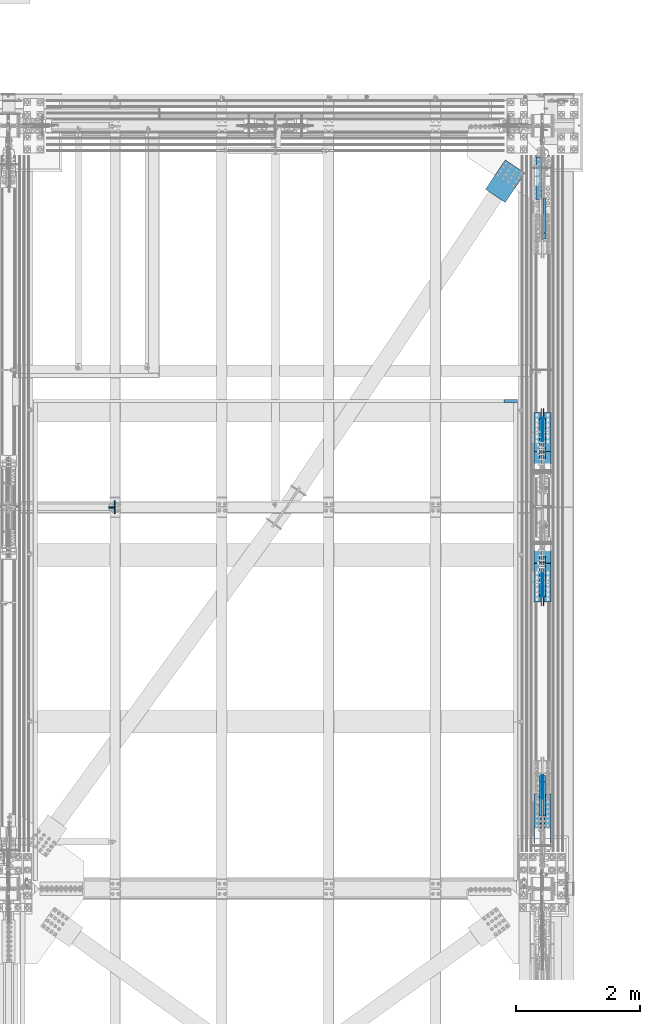
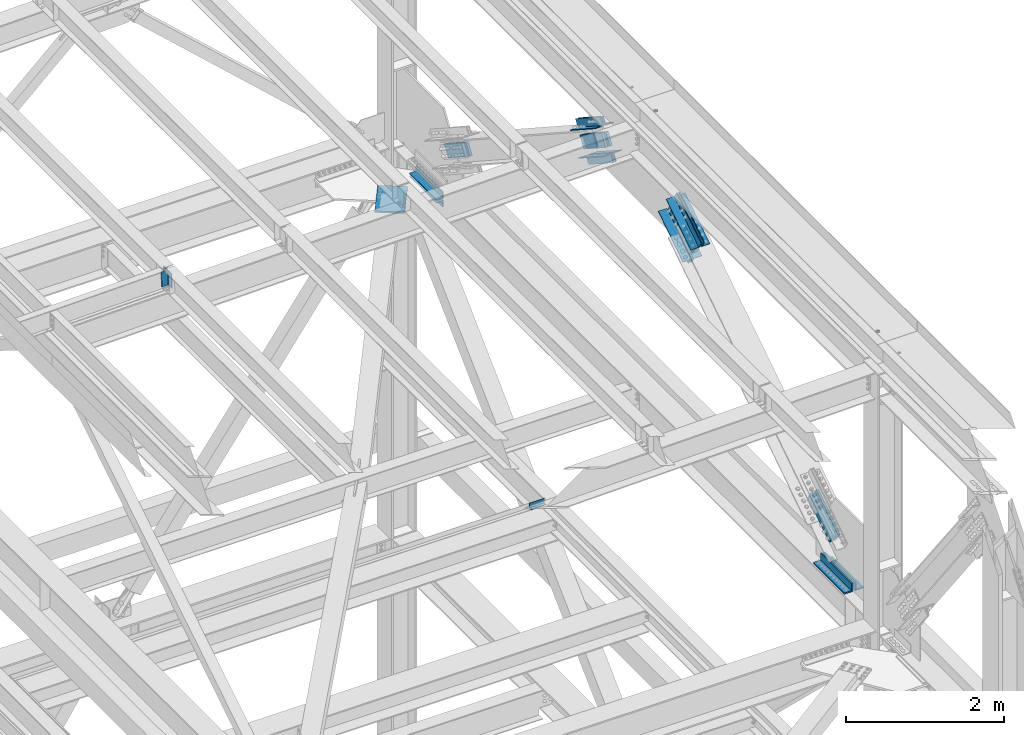
# One storey, part 2777 of 3843: 23 members, 6 beams, 8 elements without a shape of their own.
"""IFC2X3 building model written with IfcOpenShell, lengths in millimetres."""

from ifc_helpers import new_model, si_unit, frame, origin_with_axes, place, context, subcontext, project, spatial, faceted_brep, material, type_object, element, aggregate, save


model = new_model("IFC2X3")

# Units and contexts
model_context = context("Model", 3, precision=1e-05, world=origin_with_axes())
body_context = subcontext(model_context, "Body", "Model", "MODEL_VIEW")
ifc_project = project(units=[si_unit("LENGTHUNIT", "METRE", prefix="MILLI"), si_unit("AREAUNIT", "SQUARE_METRE"), si_unit("VOLUMEUNIT", "CUBIC_METRE"), si_unit("MASSUNIT", "GRAM", prefix="KILO"), si_unit("TIMEUNIT", "SECOND"), si_unit("PLANEANGLEUNIT", "RADIAN"), si_unit("SOLIDANGLEUNIT", "STERADIAN"), si_unit("THERMODYNAMICTEMPERATUREUNIT", "DEGREE_CELSIUS"), si_unit("LUMINOUSINTENSITYUNIT", "LUMEN")], contexts=[model_context])

# Site, building, storey
site_placement = place(None, origin_with_axes())
site = spatial("IfcSite", under=ifc_project, at=site_placement, CompositionType="ELEMENT")
building_placement = place(site_placement, origin_with_axes())
building = spatial("IfcBuilding", under=site, at=building_placement, Name="Undefined", CompositionType="ELEMENT")
storey_placement = place(building_placement, origin_with_axes())
storey = spatial("IfcBuildingStorey", under=building, at=storey_placement, Name="Undefined", CompositionType="ELEMENT", Elevation=0.0)

# Assembly, beams
assembly_1_placement = place(storey_placement, origin_with_axes())
assembly_1 = element("IfcElementAssembly", 1, at=assembly_1_placement, inside=storey, Name="PLATE", AssemblyPlace="NOTDEFINED", PredefinedType="RIGID_FRAME")
ifc_material_1 = material(Name="STEEL/A572-50")
beam_type_1 = type_object("IfcBeamType", Name="L4X4X1/2", PredefinedType="NOTDEFINED")
beam_1_placement = place(assembly_1_placement, frame((85591.6499999543, 103365.3, 42297.35), z_axis=(-1.0, 0.0, 0.0), x_axis=(0.0, 1.0, 0.0)))
beam_1 = element("IfcBeam", 2, at=beam_1_placement, type_object=beam_type_1, material=ifc_material_1, Name="ANGLE", ObjectType="L4X4X1/2", context=body_context, shape_type="Brep", body=[
    faceted_brep([(0.0, 50.8000000000029, -50.8000000000029), (0.0, 50.8000000000029, 50.8000000000029), (685.800000000003, 50.8000000000029, 50.8000000000029), (685.800000000003, 50.8000000000029, -50.8000000000029), (0.0, 38.0999999999985, 50.8000000000029), (685.800000000003, 38.0999999999985, 50.8000000000029), (0.0, 38.0999999999985, -38.0999999999985), (685.800000000003, 38.0999999999985, -38.1000000000058), (0.0, -50.8000000000029, -38.1000000000058), (685.800000000003, -50.8000000000029, -38.1000000000058), (0.0, -50.8000000000029, -50.8000000000029), (685.800000000003, -50.8000000000029, -50.8000000000029)], [[[0, 1, 2, 3]], [[1, 4, 5, 2]], [[4, 6, 7, 5]], [[6, 8, 9, 7]], [[8, 10, 11, 9]], [[10, 0, 3, 11]], [[5, 7, 9, 11, 3, 2]], [[10, 8, 6, 4, 1, 0]]]),
])
beam_2_placement = place(assembly_1_placement, frame((85591.6499999543, 104051.1, 42167.175), z_axis=(-1.0, 0.0, 0.0), x_axis=(0.0, -1.0, 0.0)))
beam_2 = element("IfcBeam", 3, at=beam_2_placement, type_object=beam_type_1, material=ifc_material_1, Name="ANGLE", ObjectType="L4X4X1/2", context=body_context, shape_type="Brep", body=[
    faceted_brep([(0.0, 50.8000000000029, -50.8000000000029), (0.0, 50.8000000000029, 50.8000000000029), (685.800000000003, 50.8000000000029, 50.8000000000029), (685.800000000003, 50.8000000000029, -50.8000000000029), (0.0, 38.0999999999985, 50.8000000000029), (685.800000000003, 38.0999999999985, 50.8000000000029), (0.0, 38.0999999999985, -38.0999999999985), (685.800000000003, 38.0999999999985, -38.1000000000058), (0.0, -50.8000000000029, -38.1000000000058), (685.800000000003, -50.8000000000029, -38.1000000000058), (0.0, -50.8000000000029, -50.8000000000029), (685.800000000003, -50.8000000000029, -50.8000000000029)], [[[0, 1, 2, 3]], [[1, 4, 5, 2]], [[4, 6, 7, 5]], [[6, 8, 9, 7]], [[8, 10, 11, 9]], [[10, 0, 3, 11]], [[5, 7, 9, 11, 3, 2]], [[10, 8, 6, 4, 1, 0]]]),
])
aggregate(assembly_1, [beam_1, beam_2])

# Assembly, members
assembly_2_placement = place(storey_placement, origin_with_axes())
assembly_2 = element("IfcElementAssembly", 4, at=assembly_2_placement, inside=storey, Name="BEAM", AssemblyPlace="NOTDEFINED", PredefinedType="RIGID_FRAME")
member_type_1 = type_object("IfcMemberType", Name="L4X4X3/8", PredefinedType="NOTDEFINED")
member_1_placement = place(assembly_2_placement, frame((78685.0968642702, 98440.8749999524, 46353.7300155141), z_axis=(0.0, 1.0, 0.0), x_axis=(-0.0211520980073474, 0.0, 0.999776269347241)))
member_1 = element("IfcMember", 5, at=member_1_placement, type_object=member_type_1, material=ifc_material_1, Name="ANGLE", ObjectType="L4X4X3/8", context=body_context, shape_type="Brep", body=[
    faceted_brep([(0.0, 50.8000000000029, -50.8000000000029), (0.0, 50.8000000000029, 50.8000000000029), (228.599999994367, 50.7999999996973, 50.8000000000029), (228.599999994367, 50.7999999996973, -50.8000000000029), (0.0, 41.2750000000015, 50.8000000000029), (228.599999994345, 41.2749999997031, 50.8000000000029), (0.0, 41.2749999999942, -41.2750000000015), (228.599999994345, 41.2749999997031, -41.2750000000015), (0.0, -50.8000000000029, -41.2750000000015), (228.599999994258, -50.8000000001412, -41.2750000000015), (0.0, -50.8000000000029, -50.8000000000029), (228.599999994258, -50.8000000001412, -50.8000000000029)], [[[0, 1, 2, 3]], [[1, 4, 5, 2]], [[4, 6, 7, 5]], [[6, 8, 9, 7]], [[8, 10, 11, 9]], [[10, 0, 3, 11]], [[5, 7, 9, 11, 3, 2]], [[10, 8, 6, 4, 1, 0]]]),
])
member_2_placement = place(assembly_2_placement, frame((78680.2614946649, 98332.9250000477, 46582.2788706815), z_axis=(0.0, -1.0, 0.0), x_axis=(0.0211520550054438, 0.0, -0.999776270257025)))
member_2 = element("IfcMember", 6, at=member_2_placement, type_object=member_type_1, material=ifc_material_1, Name="ANGLE", ObjectType="L4X4X3/8", context=body_context, shape_type="Brep", body=[
    faceted_brep([(0.0, 50.8000000000029, -50.8000000000029), (0.0, 50.8000000000029, 50.8000000000029), (228.599999994367, 50.7999999996973, 50.8000000000029), (228.599999994367, 50.7999999996973, -50.8000000000029), (0.0, 41.2750000000015, 50.8000000000029), (228.599999994345, 41.2749999997031, 50.8000000000029), (0.0, 41.2749999999942, -41.2750000000015), (228.599999994345, 41.2749999997031, -41.2750000000015), (0.0, -50.8000000000029, -41.2750000000015), (228.599999994258, -50.8000000001412, -41.2750000000015), (0.0, -50.8000000000029, -50.8000000000029), (228.599999994258, -50.8000000001412, -50.8000000000029)], [[[0, 1, 2, 3]], [[1, 4, 5, 2]], [[4, 6, 7, 5]], [[6, 8, 9, 7]], [[8, 10, 11, 9]], [[10, 0, 3, 11]], [[5, 7, 9, 11, 3, 2]], [[10, 8, 6, 4, 1, 0]]]),
])
aggregate(assembly_2, [member_1, member_2])

# Assembly, beam
assembly_3_placement = place(storey_placement, origin_with_axes())
assembly_3 = element("IfcElementAssembly", 7, at=assembly_3_placement, inside=storey, Name="BEAM", AssemblyPlace="NOTDEFINED", PredefinedType="RIGID_FRAME")
ifc_material_2 = material(Name="STEEL/A36")
beam_type_2 = type_object("IfcBeamType", PredefinedType="NOTDEFINED")
beam_3_placement = place(assembly_3_placement, frame((85140.80025, 100082.746884, 39627.175), z_axis=(-1.0, 0.0, 0.0), x_axis=(0.0, 1.0, 0.0)))
beam_3 = element("IfcBeam", 8, at=beam_3_placement, type_object=beam_type_2, material=ifc_material_2, Name="BENT_PLATE", context=body_context, shape_type="Brep", body=[
    faceted_brep([(0.0, -4.76939021609724e-08, 112.713000000003), (0.0, -3.17500000000291, 109.538000047687), (44.4499999999825, -3.17500000000291, 109.538000047687), (47.6249999522843, -4.76939021609724e-08, 112.713000000003), (44.4499999999825, -73.0249999999942, 109.538000047687), (47.6249999522843, -73.0249999999942, 112.713000000003), (44.4499999999825, -3.17500000000291, -112.713000000003), (44.4499999999825, -73.0249999999942, -112.713000000003), (0.0, 3.17500000000291, 112.713000000003), (0.0, 3.17500000000291, -112.713000000003), (0.0, -3.17500000000291, -112.713000000003), (50.7999999999884, 3.17500000000291, 112.713000000003), (50.7999999999884, 3.17500000000291, -112.713000000003), (50.7999999999884, -73.0249999999942, 112.713000000003), (50.7999999999884, -73.0249999999942, -112.713000000003)], [[[0, 1, 2, 3]], [[3, 2, 4, 5]], [[6, 7, 4, 2]], [[8, 9, 10, 1, 0]], [[9, 8, 11, 12]], [[10, 6, 2, 1]], [[12, 11, 13, 14]], [[13, 11, 8, 0, 3, 5]], [[6, 10, 9, 12, 14, 7]], [[7, 14, 13, 5, 4]]]),
])
aggregate(assembly_3, [beam_3])

assembly_4_placement = place(storey_placement, origin_with_axes())
assembly_4 = element("IfcElementAssembly", 9, at=assembly_4_placement, inside=storey, AssemblyPlace="NOTDEFINED", PredefinedType="RIGID_FRAME")
beam_type_3 = type_object("IfcBeamType", PredefinedType="NOTDEFINED")
beam_4_placement = place(assembly_4_placement, frame((85206.283004064, 103899.396746269, 42259.25), z_axis=(-0.830469590040634, 0.55706396402724, 0.0), x_axis=(-0.557063965179534, -0.830469589267695, 0.0)))
beam_4 = element("IfcBeam", 10, at=beam_4_placement, type_object=beam_type_3, material=ifc_material_1, Name="PLATE", context=body_context, shape_type="Brep", body=[
    faceted_brep([(5.85714587941766e-10, 12.6999999999971, -190.500000000349), (-6.14818418398499e-10, 12.6999999999971, 190.500000000364), (571.499999996191, 12.6999999999971, 190.49999999936), (571.499999997392, 12.6999999999971, -190.500000001353), (-6.14818418398499e-10, -12.6999999999971, 190.500000000364), (571.499999996191, -12.6999999999971, 190.49999999936), (5.85714587941766e-10, -12.6999999999971, -190.500000000349), (571.499999997392, -12.6999999999971, -190.500000001353)], [[[0, 1, 2, 3]], [[1, 4, 5, 2]], [[4, 6, 7, 5]], [[6, 0, 3, 7]], [[5, 7, 3, 2]], [[6, 4, 1, 0]]]),
])
aggregate(assembly_4, [beam_4])

# Assembly, member
assembly_5_placement = place(storey_placement, origin_with_axes())
assembly_5 = element("IfcElementAssembly", 11, at=assembly_5_placement, inside=storey, AssemblyPlace="NOTDEFINED", PredefinedType="RIGID_FRAME")
member_type_2 = type_object("IfcMemberType", PredefinedType="NOTDEFINED")
member_3_placement = place(assembly_5_placement, frame((85680.5499998689, 103329.322101915, 42997.8950808007), z_axis=(0.0, -0.545564039261356, -0.838069137401464), x_axis=(0.0, -0.838069137401467, 0.545564039261351)))
member_3 = element("IfcMember", 12, at=member_3_placement, type_object=member_type_2, material=ifc_material_1, Name="PLATE", context=body_context, shape_type="Brep", body=[
    faceted_brep([(1.16415321826935e-10, 19.0500000000029, -95.2500000001601), (-1.16415321826935e-10, 19.0500000000029, 95.2500000001601), (660.400000008245, 19.0500000000029, 95.2500000025429), (660.400000007954, 19.0500000000029, -95.2499999980901), (-1.16415321826935e-10, -19.0500000000029, 95.2500000001601), (660.400000008245, -19.0500000000029, 95.2500000025429), (1.16415321826935e-10, -19.0500000000029, -95.2500000001601), (660.400000007954, -19.0500000000029, -95.2499999980901)], [[[0, 1, 2, 3]], [[1, 4, 5, 2]], [[4, 6, 7, 5]], [[6, 0, 3, 7]], [[5, 7, 3, 2]], [[6, 4, 1, 0]]]),
])

# Assembly, members
assembly_6_placement = place(storey_placement, origin_with_axes())
assembly_6 = element("IfcElementAssembly", 13, at=assembly_6_placement, inside=storey, AssemblyPlace="NOTDEFINED", PredefinedType="RIGID_FRAME")
member_4_placement = place(assembly_6_placement, frame((85680.5499999863, 93444.4779012868, 42997.895080809), z_axis=(0.0, -0.545564039261356, 0.838069137401464), x_axis=(0.0, 0.838069137401467, 0.545564039261351)))
member_4 = element("IfcMember", 14, at=member_4_placement, type_object=member_type_2, material=ifc_material_1, Name="PLATE", context=body_context, shape_type="Brep", body=[
    faceted_brep([(1.16415321826935e-10, 19.0500000000029, -95.2500000001601), (-1.16415321826935e-10, 19.0500000000029, 95.2500000001601), (660.400000008245, 19.0500000000029, 95.2500000025429), (660.400000007954, 19.0500000000029, -95.2499999980901), (-1.16415321826935e-10, -19.0500000000029, 95.2500000001601), (660.400000008245, -19.0500000000029, 95.2500000025429), (1.16415321826935e-10, -19.0500000000029, -95.2500000001601), (660.400000007954, -19.0500000000029, -95.2499999980901)], [[[0, 1, 2, 3]], [[1, 4, 5, 2]], [[4, 6, 7, 5]], [[6, 0, 3, 7]], [[5, 7, 3, 2]], [[6, 4, 1, 0]]]),
])
member_5_placement = place(assembly_6_placement, frame((85617.0499999863, 93444.4779012868, 42997.895080809), z_axis=(0.0, -0.545564039261356, 0.838069137401464), x_axis=(0.0, 0.838069137401467, 0.545564039261351)))
member_5 = element("IfcMember", 15, at=member_5_placement, type_object=member_type_2, material=ifc_material_1, Name="PLATE", context=body_context, shape_type="Brep", body=[
    faceted_brep([(1.16415321826935e-10, 19.0500000000029, -95.2500000001601), (-1.16415321826935e-10, 19.0500000000029, 95.2500000001601), (660.400000008245, 19.0500000000029, 95.2500000025429), (660.400000007954, 19.0500000000029, -95.2499999980901), (-1.16415321826935e-10, -19.0500000000029, 95.2500000001601), (660.400000008245, -19.0500000000029, 95.2500000025429), (1.16415321826935e-10, -19.0500000000029, -95.2500000001601), (660.400000007954, -19.0500000000029, -95.2499999980901)], [[[0, 1, 2, 3]], [[1, 4, 5, 2]], [[4, 6, 7, 5]], [[6, 0, 3, 7]], [[5, 7, 3, 2]], [[6, 4, 1, 0]]]),
])

# Member
member_6_placement = place(assembly_5_placement, frame((85680.5499999863, 99226.2437681716, 45668.9062053753), z_axis=(0.0, 0.545564039261343, 0.838069137401472), x_axis=(0.0, 0.838069137401467, -0.545564039261352)))
member_6 = element("IfcMember", 16, at=member_6_placement, type_object=member_type_2, material=ifc_material_1, Name="PLATE", context=body_context, shape_type="Brep", body=[
    faceted_brep([(1.16415321826935e-10, 19.0500000000029, -95.2500000001601), (-1.16415321826935e-10, 19.0500000000029, 95.2500000001601), (660.400000008245, 19.0500000000029, 95.2500000025429), (660.400000007954, 19.0500000000029, -95.2499999980901), (-1.16415321826935e-10, -19.0500000000029, 95.2500000001601), (660.400000008245, -19.0500000000029, 95.2500000025429), (1.16415321826935e-10, -19.0500000000029, -95.2500000001601), (660.400000007954, -19.0500000000029, -95.2499999980901)], [[[0, 1, 2, 3]], [[1, 4, 5, 2]], [[4, 6, 7, 5]], [[6, 0, 3, 7]], [[5, 7, 3, 2]], [[6, 4, 1, 0]]]),
])

member_7_placement = place(assembly_5_placement, frame((85617.0499999863, 99226.2437681716, 45668.9062053753), z_axis=(0.0, 0.545564039261343, 0.838069137401472), x_axis=(0.0, 0.838069137401467, -0.545564039261352)))
member_7 = element("IfcMember", 17, at=member_7_placement, type_object=member_type_2, material=ifc_material_1, Name="PLATE", context=body_context, shape_type="Brep", body=[
    faceted_brep([(1.16415321826935e-10, 19.0500000000029, -95.2500000001601), (-1.16415321826935e-10, 19.0500000000029, 95.2500000001601), (660.400000008245, 19.0500000000029, 95.2500000025429), (660.400000007954, 19.0500000000029, -95.2499999980901), (-1.16415321826935e-10, -19.0500000000029, 95.2500000001601), (660.400000008245, -19.0500000000029, 95.2500000025429), (1.16415321826935e-10, -19.0500000000029, -95.2500000001601), (660.400000007954, -19.0500000000029, -95.2499999980901)], [[[0, 1, 2, 3]], [[1, 4, 5, 2]], [[4, 6, 7, 5]], [[6, 0, 3, 7]], [[5, 7, 3, 2]], [[6, 4, 1, 0]]]),
])

member_8_placement = place(assembly_6_placement, frame((85680.5499999863, 97547.556235026, 45668.9062053805), z_axis=(0.0, 0.545564039261343, -0.838069137401472), x_axis=(0.0, -0.838069137401464, -0.545564039261356)))
member_8 = element("IfcMember", 18, at=member_8_placement, type_object=member_type_2, material=ifc_material_1, Name="PLATE", context=body_context, shape_type="Brep", body=[
    faceted_brep([(1.16415321826935e-10, 19.0500000000029, -95.2500000001601), (-1.16415321826935e-10, 19.0500000000029, 95.2500000001601), (660.400000008245, 19.0500000000029, 95.2500000025429), (660.400000007954, 19.0500000000029, -95.2499999980901), (-1.16415321826935e-10, -19.0500000000029, 95.2500000001601), (660.400000008245, -19.0500000000029, 95.2500000025429), (1.16415321826935e-10, -19.0500000000029, -95.2500000001601), (660.400000007954, -19.0500000000029, -95.2499999980901)], [[[0, 1, 2, 3]], [[1, 4, 5, 2]], [[4, 6, 7, 5]], [[6, 0, 3, 7]], [[5, 7, 3, 2]], [[6, 4, 1, 0]]]),
])

member_9_placement = place(assembly_6_placement, frame((85617.0499999863, 97547.556235026, 45668.9062053805), z_axis=(0.0, 0.545564039261343, -0.838069137401472), x_axis=(0.0, -0.838069137401464, -0.545564039261356)))
member_9 = element("IfcMember", 19, at=member_9_placement, type_object=member_type_2, material=ifc_material_1, Name="PLATE", context=body_context, shape_type="Brep", body=[
    faceted_brep([(1.16415321826935e-10, 19.0500000000029, -95.2500000001601), (-1.16415321826935e-10, 19.0500000000029, 95.2500000001601), (660.400000008245, 19.0500000000029, 95.2500000025429), (660.400000007954, 19.0500000000029, -95.2499999980901), (-1.16415321826935e-10, -19.0500000000029, 95.2500000001601), (660.400000008245, -19.0500000000029, 95.2500000025429), (1.16415321826935e-10, -19.0500000000029, -95.2500000001601), (660.400000007954, -19.0500000000029, -95.2499999980901)], [[[0, 1, 2, 3]], [[1, 4, 5, 2]], [[4, 6, 7, 5]], [[6, 0, 3, 7]], [[5, 7, 3, 2]], [[6, 4, 1, 0]]]),
])

member_type_3 = type_object("IfcMemberType", Name="L5X5X1/2", PredefinedType="NOTDEFINED")
member_10_placement = place(assembly_5_placement, frame((85724.9999999863, 99320.6361976878, 45895.3826097803), z_axis=(0.0, 0.545564039261343, 0.838069137401472), x_axis=(0.0, 0.838069137401467, -0.545564039261352)))
member_10 = element("IfcMember", 20, at=member_10_placement, type_object=member_type_3, material=ifc_material_1, Name="ANGLE", ObjectType="L5X5X1/2", context=body_context, shape_type="Brep", body=[
    faceted_brep([(-1.01863406598568e-10, 63.5, -63.5000000002037), (1.01863406598568e-10, 63.5, 63.5000000002074), (749.300000016152, 63.5, 63.4999999992142), (749.300000016028, 63.5, -63.5000000006548), (1.01863406598568e-10, 50.8000000000029, 63.5000000002074), (749.300000016152, 50.8000000000029, 63.4999999992142), (0.0, 50.8000000000029, -50.8000000000029), (749.30000001605, 50.8000000000029, -50.8000000006577), (-7.27595761418343e-11, -63.5, -50.8000000001666), (749.30000001605, -63.5, -50.8000000006577), (-1.01863406598568e-10, -63.5, -63.5000000002037), (749.300000016028, -63.5, -63.5000000006548)], [[[0, 1, 2, 3]], [[1, 4, 5, 2]], [[4, 6, 7, 5]], [[6, 8, 9, 7]], [[8, 10, 11, 9]], [[10, 0, 3, 11]], [[5, 7, 9, 11, 3, 2]], [[10, 8, 6, 4, 1, 0]]]),
])

member_11_placement = place(assembly_5_placement, frame((85724.9999999863, 99685.3121970061, 45082.1393094363), z_axis=(0.0, -0.545564039261356, -0.838069137401464), x_axis=(0.0, -0.838069137401467, 0.545564039261351)))
member_11 = element("IfcMember", 21, at=member_11_placement, type_object=member_type_3, material=ifc_material_1, Name="ANGLE", ObjectType="L5X5X1/2", context=body_context, shape_type="Brep", body=[
    faceted_brep([(-1.01863406598568e-10, 63.5, -63.5000000002037), (1.01863406598568e-10, 63.5, 63.5000000002074), (749.300000016152, 63.5, 63.4999999992142), (749.300000016028, 63.5, -63.5000000006548), (1.01863406598568e-10, 50.8000000000029, 63.5000000002074), (749.300000016152, 50.8000000000029, 63.4999999992142), (0.0, 50.8000000000029, -50.8000000000029), (749.30000001605, 50.8000000000029, -50.8000000006577), (-7.27595761418343e-11, -63.5, -50.8000000001666), (749.30000001605, -63.5, -50.8000000006577), (-1.01863406598568e-10, -63.5, -63.5000000002037), (749.300000016028, -63.5, -63.5000000006548)], [[[0, 1, 2, 3]], [[1, 4, 5, 2]], [[4, 6, 7, 5]], [[6, 8, 9, 7]], [[8, 10, 11, 9]], [[10, 0, 3, 11]], [[5, 7, 9, 11, 3, 2]], [[10, 8, 6, 4, 1, 0]]]),
])

member_12_placement = place(assembly_5_placement, frame((85572.5999999863, 99948.6014023575, 45486.5914751536), z_axis=(0.0, 0.545564039261343, 0.838069137401472), x_axis=(0.0, -0.838069137401467, 0.545564039261351)))
member_12 = element("IfcMember", 22, at=member_12_placement, type_object=member_type_3, material=ifc_material_1, Name="ANGLE", ObjectType="L5X5X1/2", context=body_context, shape_type="Brep", body=[
    faceted_brep([(-1.01863406598568e-10, 63.5, -63.5000000002037), (1.01863406598568e-10, 63.5, 63.5000000002074), (749.300000016152, 63.5, 63.4999999992142), (749.300000016028, 63.5, -63.5000000006548), (1.01863406598568e-10, 50.8000000000029, 63.5000000002074), (749.300000016152, 50.8000000000029, 63.4999999992142), (0.0, 50.8000000000029, -50.8000000000029), (749.30000001605, 50.8000000000029, -50.8000000006577), (-7.27595761418343e-11, -63.5, -50.8000000001666), (749.30000001605, -63.5, -50.8000000006577), (-1.01863406598568e-10, -63.5, -63.5000000002037), (749.300000016028, -63.5, -63.5000000006548)], [[[0, 1, 2, 3]], [[1, 4, 5, 2]], [[4, 6, 7, 5]], [[6, 8, 9, 7]], [[8, 10, 11, 9]], [[10, 0, 3, 11]], [[5, 7, 9, 11, 3, 2]], [[10, 8, 6, 4, 1, 0]]]),
])

member_13_placement = place(assembly_5_placement, frame((85572.5999999863, 99057.3469923364, 45490.930444063), z_axis=(0.0, -0.545564039261356, -0.838069137401464), x_axis=(0.0, 0.838069137401467, -0.545564039261352)))
member_13 = element("IfcMember", 23, at=member_13_placement, type_object=member_type_3, material=ifc_material_1, Name="ANGLE", ObjectType="L5X5X1/2", context=body_context, shape_type="Brep", body=[
    faceted_brep([(-1.01863406598568e-10, 63.5, -63.5000000002037), (1.01863406598568e-10, 63.5, 63.5000000002074), (749.300000016152, 63.5, 63.4999999992142), (749.300000016028, 63.5, -63.5000000006548), (1.01863406598568e-10, 50.8000000000029, 63.5000000002074), (749.300000016152, 50.8000000000029, 63.4999999992142), (0.0, 50.8000000000029, -50.8000000000029), (749.30000001605, 50.8000000000029, -50.8000000006577), (-7.27595761418343e-11, -63.5, -50.8000000001666), (749.30000001605, -63.5, -50.8000000006577), (-1.01863406598568e-10, -63.5, -63.5000000002037), (749.300000016028, -63.5, -63.5000000006548)], [[[0, 1, 2, 3]], [[1, 4, 5, 2]], [[4, 6, 7, 5]], [[6, 8, 9, 7]], [[8, 10, 11, 9]], [[10, 0, 3, 11]], [[5, 7, 9, 11, 3, 2]], [[10, 8, 6, 4, 1, 0]]]),
])

member_14_placement = place(assembly_6_placement, frame((85724.9999999863, 97716.4530108612, 45490.9304440682), z_axis=(0.0, 0.545564039261343, -0.838069137401472), x_axis=(0.0, -0.838069137401464, -0.545564039261356)))
member_14 = element("IfcMember", 24, at=member_14_placement, type_object=member_type_3, material=ifc_material_1, Name="ANGLE", ObjectType="L5X5X1/2", context=body_context, shape_type="Brep", body=[
    faceted_brep([(-1.01863406598568e-10, 63.5, -63.5000000002037), (1.01863406598568e-10, 63.5, 63.5000000002074), (749.300000016152, 63.5, 63.4999999992142), (749.300000016028, 63.5, -63.5000000006548), (1.01863406598568e-10, 50.8000000000029, 63.5000000002074), (749.300000016152, 50.8000000000029, 63.4999999992142), (0.0, 50.8000000000029, -50.8000000000029), (749.30000001605, 50.8000000000029, -50.8000000006577), (-7.27595761418343e-11, -63.5, -50.8000000001666), (749.30000001605, -63.5, -50.8000000006577), (-1.01863406598568e-10, -63.5, -63.5000000002037), (749.300000016028, -63.5, -63.5000000006548)], [[[0, 1, 2, 3]], [[1, 4, 5, 2]], [[4, 6, 7, 5]], [[6, 8, 9, 7]], [[8, 10, 11, 9]], [[10, 0, 3, 11]], [[5, 7, 9, 11, 3, 2]], [[10, 8, 6, 4, 1, 0]]]),
])

member_15_placement = place(assembly_6_placement, frame((85724.9999999863, 96825.19860084, 45486.5914751588), z_axis=(0.0, -0.545564039261356, 0.838069137401464), x_axis=(0.0, 0.838069137401467, 0.545564039261351)))
member_15 = element("IfcMember", 25, at=member_15_placement, type_object=member_type_3, material=ifc_material_1, Name="ANGLE", ObjectType="L5X5X1/2", context=body_context, shape_type="Brep", body=[
    faceted_brep([(-1.01863406598568e-10, 63.5, -63.5000000002037), (1.01863406598568e-10, 63.5, 63.5000000002074), (749.300000016152, 63.5, 63.4999999992142), (749.300000016028, 63.5, -63.5000000006548), (1.01863406598568e-10, 50.8000000000029, 63.5000000002074), (749.300000016152, 50.8000000000029, 63.4999999992142), (0.0, 50.8000000000029, -50.8000000000029), (749.30000001605, 50.8000000000029, -50.8000000006577), (-7.27595761418343e-11, -63.5, -50.8000000001666), (749.30000001605, -63.5, -50.8000000006577), (-1.01863406598568e-10, -63.5, -63.5000000002037), (749.300000016028, -63.5, -63.5000000006548)], [[[0, 1, 2, 3]], [[1, 4, 5, 2]], [[4, 6, 7, 5]], [[6, 8, 9, 7]], [[8, 10, 11, 9]], [[10, 0, 3, 11]], [[5, 7, 9, 11, 3, 2]], [[10, 8, 6, 4, 1, 0]]]),
])

member_16_placement = place(assembly_6_placement, frame((85572.5999999863, 97088.4878061914, 45082.1393094415), z_axis=(0.0, 0.545564039261343, -0.838069137401472), x_axis=(0.0, 0.838069137401467, 0.545564039261351)))
member_16 = element("IfcMember", 26, at=member_16_placement, type_object=member_type_3, material=ifc_material_1, Name="ANGLE", ObjectType="L5X5X1/2", context=body_context, shape_type="Brep", body=[
    faceted_brep([(-1.01863406598568e-10, 63.5, -63.5000000002037), (1.01863406598568e-10, 63.5, 63.5000000002074), (749.300000016152, 63.5, 63.4999999992142), (749.300000016028, 63.5, -63.5000000006548), (1.01863406598568e-10, 50.8000000000029, 63.5000000002074), (749.300000016152, 50.8000000000029, 63.4999999992142), (0.0, 50.8000000000029, -50.8000000000029), (749.30000001605, 50.8000000000029, -50.8000000006577), (-7.27595761418343e-11, -63.5, -50.8000000001666), (749.30000001605, -63.5, -50.8000000006577), (-1.01863406598568e-10, -63.5, -63.5000000002037), (749.300000016028, -63.5, -63.5000000006548)], [[[0, 1, 2, 3]], [[1, 4, 5, 2]], [[4, 6, 7, 5]], [[6, 8, 9, 7]], [[8, 10, 11, 9]], [[10, 0, 3, 11]], [[5, 7, 9, 11, 3, 2]], [[10, 8, 6, 4, 1, 0]]]),
])

member_17_placement = place(assembly_6_placement, frame((85572.5999999863, 97453.1638055098, 45895.3826097856), z_axis=(0.0, -0.545564039261356, 0.838069137401464), x_axis=(0.0, -0.838069137401464, -0.545564039261356)))
member_17 = element("IfcMember", 27, at=member_17_placement, type_object=member_type_3, material=ifc_material_1, Name="ANGLE", ObjectType="L5X5X1/2", context=body_context, shape_type="Brep", body=[
    faceted_brep([(-1.01863406598568e-10, 63.5, -63.5000000002037), (1.01863406598568e-10, 63.5, 63.5000000002074), (749.300000016152, 63.5, 63.4999999992142), (749.300000016028, 63.5, -63.5000000006548), (1.01863406598568e-10, 50.8000000000029, 63.5000000002074), (749.300000016152, 50.8000000000029, 63.4999999992142), (0.0, 50.8000000000029, -50.8000000000029), (749.30000001605, 50.8000000000029, -50.8000000006577), (-7.27595761418343e-11, -63.5, -50.8000000001666), (749.30000001605, -63.5, -50.8000000006577), (-1.01863406598568e-10, -63.5, -63.5000000002037), (749.300000016028, -63.5, -63.5000000006548)], [[[0, 1, 2, 3]], [[1, 4, 5, 2]], [[4, 6, 7, 5]], [[6, 8, 9, 7]], [[8, 10, 11, 9]], [[10, 0, 3, 11]], [[5, 7, 9, 11, 3, 2]], [[10, 8, 6, 4, 1, 0]]]),
])

member_type_4 = type_object("IfcMemberType", PredefinedType="NOTDEFINED")
member_18_placement = place(assembly_6_placement, frame((85657.5312499863, 93726.5300694836, 43181.5046582246), z_axis=(0.0, -0.545564039261356, 0.838069137401464), x_axis=(0.0, 0.838069137401467, 0.545564039261351)))
member_18 = element("IfcMember", 28, at=member_18_placement, type_object=member_type_4, material=ifc_material_1, Name="PLATE", context=body_context, shape_type="Brep", body=[
    faceted_brep([(0.0, 3.17499999999927, -95.25), (-2.44140610448085e-05, 3.17500000000291, 95.2499999999927), (323.850000004109, 3.17500000000291, 95.2500000014152), (323.850000003833, 3.17500000000291, -95.2499999992106), (0.0, -3.17499999999927, 95.25), (323.850000004109, -3.17500000000291, 95.2500000014152), (0.0, -3.17499999999927, -95.25), (323.850000003833, -3.17500000000291, -95.2499999992106)], [[[0, 1, 2, 3]], [[1, 4, 5, 2]], [[4, 6, 7, 5]], [[6, 0, 3, 7]], [[5, 7, 3, 2]], [[6, 4, 1, 0]]]),
])

member_19_placement = place(assembly_6_placement, frame((85640.0687499863, 93726.5300694836, 43181.5046582246), z_axis=(0.0, -0.545564039261356, 0.838069137401464), x_axis=(0.0, 0.838069137401467, 0.545564039261351)))
member_19 = element("IfcMember", 29, at=member_19_placement, type_object=member_type_4, material=ifc_material_1, Name="PLATE", context=body_context, shape_type="Brep", body=[
    faceted_brep([(0.0, 3.17499999999927, -95.25), (-2.44140610448085e-05, 3.17500000000291, 95.2499999999927), (323.850000004109, 3.17500000000291, 95.2500000014152), (323.850000003833, 3.17500000000291, -95.2499999992106), (0.0, -3.17499999999927, 95.25), (323.850000004109, -3.17500000000291, 95.2500000014152), (0.0, -3.17499999999927, -95.25), (323.850000003833, -3.17500000000291, -95.2499999992106)], [[[0, 1, 2, 3]], [[1, 4, 5, 2]], [[4, 6, 7, 5]], [[6, 0, 3, 7]], [[5, 7, 3, 2]], [[6, 4, 1, 0]]]),
])

member_20_placement = place(assembly_5_placement, frame((85658.3249999863, 99508.2959363695, 45485.296627959), z_axis=(0.0, 0.545564039261343, 0.838069137401472), x_axis=(0.0, 0.838069137401467, -0.545564039261352)))
member_20 = element("IfcMember", 30, at=member_20_placement, type_object=member_type_4, material=ifc_material_1, Name="PLATE", context=body_context, shape_type="Brep", body=[
    faceted_brep([(0.0, 3.17499999999927, -95.25), (-2.44140610448085e-05, 3.17500000000291, 95.2499999999927), (323.850000004109, 3.17500000000291, 95.2500000014152), (323.850000003833, 3.17500000000291, -95.2499999992106), (0.0, -3.17499999999927, 95.25), (323.850000004109, -3.17500000000291, 95.2500000014152), (0.0, -3.17499999999927, -95.25), (323.850000003833, -3.17500000000291, -95.2499999992106)], [[[0, 1, 2, 3]], [[1, 4, 5, 2]], [[4, 6, 7, 5]], [[6, 0, 3, 7]], [[5, 7, 3, 2]], [[6, 4, 1, 0]]]),
])

member_21_placement = place(assembly_5_placement, frame((85639.2749999863, 99508.2959363695, 45485.296627959), z_axis=(0.0, -0.545564039261356, -0.838069137401464), x_axis=(0.0, 0.838069137401467, -0.545564039261352)))
member_21 = element("IfcMember", 31, at=member_21_placement, type_object=member_type_4, material=ifc_material_1, Name="PLATE", context=body_context, shape_type="Brep", body=[
    faceted_brep([(0.0, 3.17499999999927, -95.25), (-2.44140610448085e-05, 3.17500000000291, 95.2499999999927), (323.850000004109, 3.17500000000291, 95.2500000014152), (323.850000003833, 3.17500000000291, -95.2499999992106), (0.0, -3.17499999999927, 95.25), (323.850000004109, -3.17500000000291, 95.2500000014152), (0.0, -3.17499999999927, -95.25), (323.850000003833, -3.17500000000291, -95.2499999992106)], [[[0, 1, 2, 3]], [[1, 4, 5, 2]], [[4, 6, 7, 5]], [[6, 0, 3, 7]], [[5, 7, 3, 2]], [[6, 4, 1, 0]]]),
])

aggregate(assembly_5, [member_3, member_10, member_11, member_6, member_12, member_13, member_20, member_21, member_7])

member_22_placement = place(assembly_6_placement, frame((85658.3249999863, 97265.504066828, 45485.2966279642), z_axis=(0.0, 0.545564039261343, -0.838069137401472), x_axis=(0.0, -0.838069137401464, -0.545564039261356)))
member_22 = element("IfcMember", 32, at=member_22_placement, type_object=member_type_4, material=ifc_material_1, Name="PLATE", context=body_context, shape_type="Brep", body=[
    faceted_brep([(0.0, 3.17499999999927, -95.25), (-2.44140610448085e-05, 3.17500000000291, 95.2499999999927), (323.850000004109, 3.17500000000291, 95.2500000014152), (323.850000003833, 3.17500000000291, -95.2499999992106), (0.0, -3.17499999999927, 95.25), (323.850000004109, -3.17500000000291, 95.2500000014152), (0.0, -3.17499999999927, -95.25), (323.850000003833, -3.17500000000291, -95.2499999992106)], [[[0, 1, 2, 3]], [[1, 4, 5, 2]], [[4, 6, 7, 5]], [[6, 0, 3, 7]], [[5, 7, 3, 2]], [[6, 4, 1, 0]]]),
])

member_23_placement = place(assembly_6_placement, frame((85639.2749999863, 97265.504066828, 45485.2966279642), z_axis=(0.0, -0.545564039261356, 0.838069137401464), x_axis=(0.0, -0.838069137401464, -0.545564039261356)))
member_23 = element("IfcMember", 33, at=member_23_placement, type_object=member_type_4, material=ifc_material_1, Name="PLATE", context=body_context, shape_type="Brep", body=[
    faceted_brep([(0.0, 3.17499999999927, -95.25), (-2.44140610448085e-05, 3.17500000000291, 95.2499999999927), (323.850000004109, 3.17500000000291, 95.2500000014152), (323.850000003833, 3.17500000000291, -95.2499999992106), (0.0, -3.17499999999927, 95.25), (323.850000004109, -3.17500000000291, 95.2500000014152), (0.0, -3.17499999999927, -95.25), (323.850000003833, -3.17500000000291, -95.2499999992106)], [[[0, 1, 2, 3]], [[1, 4, 5, 2]], [[4, 6, 7, 5]], [[6, 0, 3, 7]], [[5, 7, 3, 2]], [[6, 4, 1, 0]]]),
])

aggregate(assembly_6, [member_4, member_18, member_19, member_5, member_14, member_15, member_8, member_16, member_17, member_22, member_23, member_9])

# Assembly, beam
assembly_7_placement = place(storey_placement, origin_with_axes())
assembly_7 = element("IfcElementAssembly", 34, at=assembly_7_placement, inside=storey, Name="ANGLE", AssemblyPlace="NOTDEFINED", PredefinedType="RIGID_FRAME")
beam_type_4 = type_object("IfcBeamType", Name="L5X5X3/4", PredefinedType="NOTDEFINED")
beam_5_placement = place(assembly_7_placement, frame((85724.9999999863, 92958.4437500013, 42532.2999999999), z_axis=(0.0, 0.0, 1.0), x_axis=(0.0, 1.0, 0.0)))
beam_5 = element("IfcBeam", 35, at=beam_5_placement, type_object=beam_type_4, material=ifc_material_1, Name="ANGLE", ObjectType="L5X5X3/4", context=body_context, shape_type="Brep", body=[
    faceted_brep([(-1.01863406598568e-10, 63.5, -63.5000000002037), (1.01863406598568e-10, 63.5, 63.5000000002074), (787.399999999994, 63.5, 63.5), (787.399999999994, 63.5, -63.5), (0.0, 44.4499999999971, 63.5), (787.399999999994, 44.4499999999971, 63.5), (-3.63797880709171e-12, 44.4499999999971, -44.4500000000007), (787.399999999994, 44.4499999999971, -44.4499999999971), (0.0, -63.5, -44.4499999999971), (787.399999999994, -63.5, -44.4499999999971), (-1.01863406598568e-10, -63.5, -63.5000000002037), (787.399999999994, -63.5, -63.5)], [[[0, 1, 2, 3]], [[1, 4, 5, 2]], [[4, 6, 7, 5]], [[6, 8, 9, 7]], [[8, 10, 11, 9]], [[10, 0, 3, 11]], [[5, 7, 9, 11, 3, 2]], [[10, 8, 6, 4, 1, 0]]]),
])
aggregate(assembly_7, [beam_5])

assembly_8_placement = place(storey_placement, origin_with_axes())
assembly_8 = element("IfcElementAssembly", 36, at=assembly_8_placement, inside=storey, Name="ANGLE", AssemblyPlace="NOTDEFINED", PredefinedType="RIGID_FRAME")
beam_6_placement = place(assembly_8_placement, frame((85572.5999999863, 93745.8437500013, 42532.3000000005), z_axis=(0.0, 0.0, 1.0), x_axis=(0.0, -1.0, 0.0)))
beam_6 = element("IfcBeam", 37, at=beam_6_placement, type_object=beam_type_4, material=ifc_material_1, Name="ANGLE", ObjectType="L5X5X3/4", context=body_context, shape_type="Brep", body=[
    faceted_brep([(-1.01863406598568e-10, 63.5, -63.5000000002037), (1.01863406598568e-10, 63.5, 63.5000000002074), (787.399999999994, 63.5, 63.5), (787.399999999994, 63.5, -63.5), (0.0, 44.4499999999971, 63.5), (787.399999999994, 44.4499999999971, 63.5), (-3.63797880709171e-12, 44.4499999999971, -44.4500000000007), (787.399999999994, 44.4499999999971, -44.4499999999971), (0.0, -63.5, -44.4499999999971), (787.399999999994, -63.5, -44.4499999999971), (-1.01863406598568e-10, -63.5, -63.5000000002037), (787.399999999994, -63.5, -63.5)], [[[0, 1, 2, 3]], [[1, 4, 5, 2]], [[4, 6, 7, 5]], [[6, 8, 9, 7]], [[8, 10, 11, 9]], [[10, 0, 3, 11]], [[5, 7, 9, 11, 3, 2]], [[10, 8, 6, 4, 1, 0]]]),
])
aggregate(assembly_8, [beam_6])

save(model, "model.ifc")
